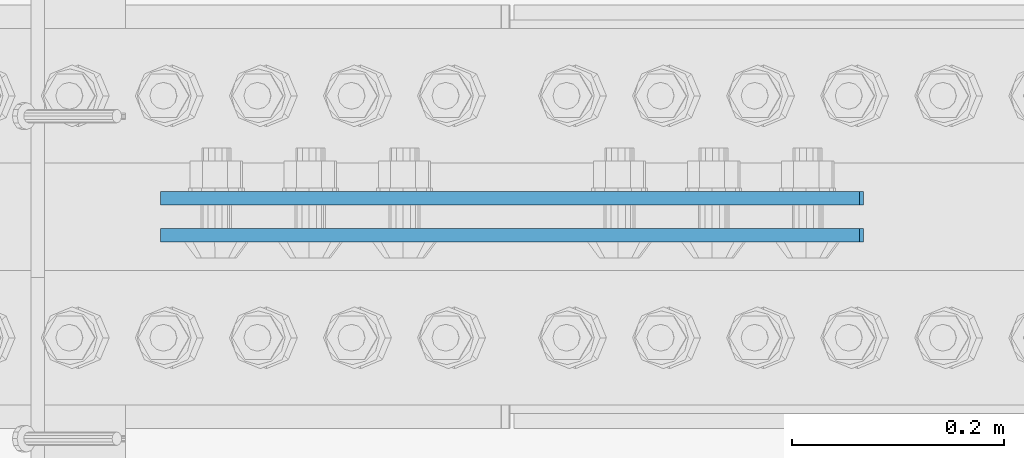
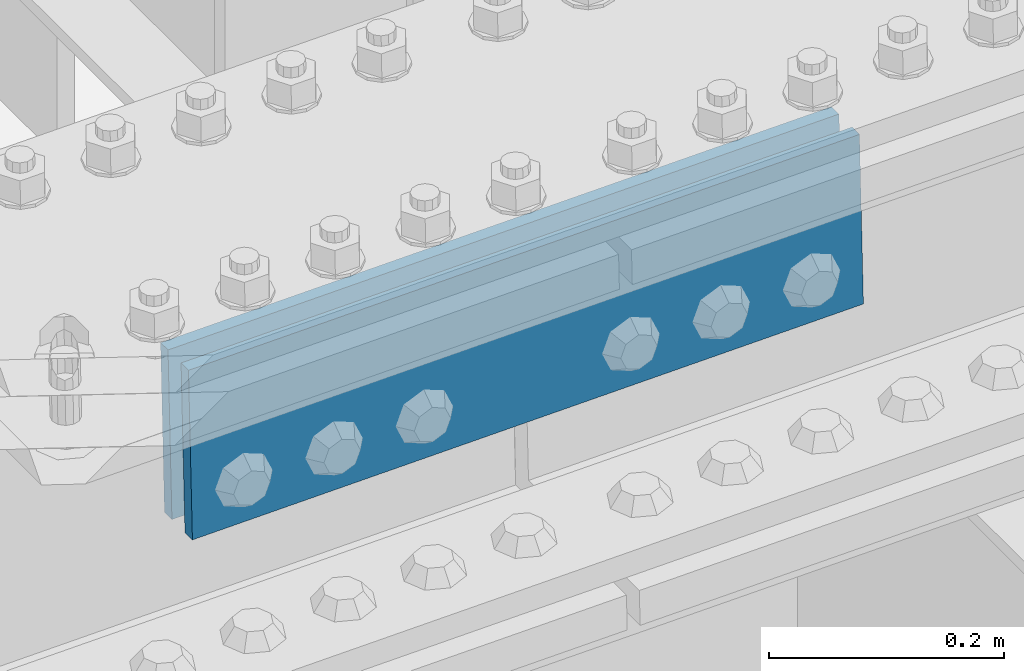
# One storey, part 2526 of 3843: 2 beams, 1 element without a shape of its own.
"""IFC2X3 building model written with IfcOpenShell, lengths in millimetres."""

import ifcopenshell
import ifcopenshell.guid

model = None  # the IFC model being written
_history = None  # IfcOwnerHistory: only IFC2X3 demands one
_inside = {}  # id of a spatial element -> (the spatial element, [elements in it])
_under = {}  # id of a project, library or spatial element -> (it, [spatial elements below it])
_declared = {}  # id of a project -> (the project, [libraries it declares])
_typed = {}  # id of a type object -> (the type object, [elements of that type])
_made_of = {}  # id of a material, layer set ... -> (it, [elements and type objects made of it])


def new_model(schema):
    """Start an empty IFC model of exactly this schema.

    Asked for "IFC4X3", IfcOpenShell would pick the latest addendum, in which some entities
    have other attributes; the version numbers below select the first issue.
    IFC2X3 requires an IfcOwnerHistory on every rooted entity: one is made here for all.
    """
    global model, _history
    if schema == "IFC4X3":
        model = ifcopenshell.file(schema_version=(4, 3, 0, 0))
    else:
        model = ifcopenshell.file(schema=schema)
    _inside.clear()
    _under.clear()
    _declared.clear()
    _typed.clear()
    _made_of.clear()
    _history = None
    if model.schema == "IFC2X3":
        org = make("IfcOrganization", Name="unknown")
        user = make(
            "IfcPersonAndOrganization",
            ThePerson=make("IfcPerson", FamilyName="unknown"),
            TheOrganization=org,
        )
        app = make(
            "IfcApplication",
            ApplicationDeveloper=org,
            Version="unknown",
            ApplicationFullName="unknown",
            ApplicationIdentifier="unknown",
        )
        _history = make(
            "IfcOwnerHistory",
            OwningUser=user,
            OwningApplication=app,
            ChangeAction="ADDED",
            CreationDate=0,
        )
    return model


def make(cls, **values):
    """One entity of the class cls with the attributes given. An attribute that is None is left unset."""
    return model.create_entity(
        cls, **{name: value for name, value in values.items() if value is not None}
    )


def rooted(cls, **values):
    """An entity with a GlobalId (a new one), such as an element, a storey or a relation."""
    return make(cls, GlobalId=ifcopenshell.guid.new(), OwnerHistory=_history, **values)


def si_unit(unit_type, name, prefix=None):
    """IfcSIUnit, for example si_unit("LENGTHUNIT", "METRE", prefix="MILLI")."""
    return make("IfcSIUnit", UnitType=unit_type, Prefix=prefix, Name=name)


def assignment(units):
    """IfcUnitAssignment: the units of a project."""
    return None if units is None else make("IfcUnitAssignment", Units=units)


def point(xyz):
    """IfcCartesianPoint."""
    return None if xyz is None else make("IfcCartesianPoint", Coordinates=xyz)


def direction(xyz):
    """IfcDirection."""
    return None if xyz is None else make("IfcDirection", DirectionRatios=xyz)


def frame(location, z_axis=None, x_axis=None):
    """IfcAxis2Placement3D, a coordinate frame: its origin and axes. An axis left out is left unset."""
    return make(
        "IfcAxis2Placement3D",
        Location=point(location),
        Axis=direction(z_axis),
        RefDirection=direction(x_axis),
    )


def origin_with_axes():
    """The frame at (0, 0, 0) with the z axis (0, 0, 1) and the x axis (1, 0, 0) written out."""
    return frame((0.0, 0.0, 0.0), z_axis=(0.0, 0.0, 1.0), x_axis=(1.0, 0.0, 0.0))


def place(relative_to, where):
    """IfcLocalPlacement: puts the frame where relative to a parent placement (None: the world)."""
    return make(
        "IfcLocalPlacement", PlacementRelTo=relative_to, RelativePlacement=where
    )


def context(
    kind, dimensions, precision=None, world=None, true_north=None, identifier=None
):
    """IfcGeometricRepresentationContext, for example the 3D "Model" context."""
    return make(
        "IfcGeometricRepresentationContext",
        ContextIdentifier=identifier,
        ContextType=kind,
        CoordinateSpaceDimension=dimensions,
        Precision=precision,
        WorldCoordinateSystem=world,
        TrueNorth=true_north,
    )


def subcontext(parent, identifier, kind, view, scale=None):
    """IfcGeometricRepresentationSubContext, for example "Body" below "Model"."""
    return make(
        "IfcGeometricRepresentationSubContext",
        ContextIdentifier=identifier,
        ContextType=kind,
        ParentContext=parent,
        TargetScale=scale,
        TargetView=view,
    )


def project(units=None, contexts=None):
    """IfcProject with its units and contexts."""
    return rooted(
        "IfcProject",
        Name="project",
        RepresentationContexts=contexts,
        UnitsInContext=assignment(units),
    )


def spatial(cls, under=None, at=None, **own):
    """A site, building, storey or space (cls), placed at a placement, below another one or the project."""
    s = rooted(cls, ObjectPlacement=at, **own)
    if under is not None:
        _under.setdefault(under.id(), (under, []))[1].append(s)
    return s


def faces_of(points, faces, orient=None, outer=None):
    """IfcFace entities. A face is a list of loops; a loop is a list of indices into points, from 0.

    orient and outer hold one flag for each loop. By default every Orientation is true, the
    first loop of a face is its IfcFaceOuterBound and the others are IfcFaceBound.
    """
    made = []
    for i, loops in enumerate(faces):
        bounds = []
        for j, loop in enumerate(loops):
            is_outer = j == 0 if outer is None else outer[i][j]
            bounds.append(
                make(
                    "IfcFaceOuterBound" if is_outer else "IfcFaceBound",
                    Bound=make("IfcPolyLoop", Polygon=[points[k] for k in loop]),
                    Orientation=True if orient is None else orient[i][j],
                )
            )
        made.append(make("IfcFace", Bounds=bounds))
    return made


def faceted_brep(points, faces, orient=None, outer=None, voids=None):
    """IfcFacetedBrep: a solid bounded by flat faces; with voids (closed shells), ...WithVoids."""
    shared = [point(p) for p in points]
    hull = make("IfcClosedShell", CfsFaces=faces_of(shared, faces, orient, outer))
    if voids is None:
        return make("IfcFacetedBrep", Outer=hull)
    return make(
        "IfcFacetedBrepWithVoids",
        Outer=hull,
        Voids=[
            make(cls, CfsFaces=faces_of(shared, fs, o, b)) for cls, fs, o, b in voids
        ],
    )


def shape(context_of_items, identifier, shape_type, items):
    """IfcShapeRepresentation: the items that make up one representation, for example the "Body"."""
    return make(
        "IfcShapeRepresentation",
        ContextOfItems=context_of_items,
        RepresentationIdentifier=identifier,
        RepresentationType=shape_type,
        Items=items,
    )


def material(Name=None, Category=None):
    """IfcMaterial."""
    return make("IfcMaterial", Name=Name, Category=Category)


def made_of(thing, what):
    """Note that an element or type object is made of a material, layer set ...; save() writes the relation."""
    if what is not None:
        _made_of.setdefault(what.id(), (what, []))[1].append(thing)
    return thing


def type_object(cls, material=None, **own):
    """A type object (cls), such as IfcWallType, which elements share."""
    return made_of(rooted(cls, **own), material)


def element(
    cls,
    number,
    at=None,
    inside=None,
    cuts=None,
    type_object=None,
    material=None,
    context=None,
    identifier="Body",
    shape_type=None,
    held_by="IfcProductDefinitionShape",
    body=None,
    shapes=None,
    **own,
):
    """One element of the class cls, such as IfcWall. Its Tag is "e" and its number.

    at: its placement. inside: the storey or other place that contains it. cuts: it is an
    opening in that element (IfcRelVoidsElement). A single representation is given by context,
    identifier, shape_type and body (its items); several are given by shapes. held_by: the class
    of the entity that holds the representations. save() writes the other relations.
    """
    e = rooted(cls, Tag="e%d" % number, ObjectPlacement=at, **own)
    if body is not None:
        shapes = [shape(context, identifier, shape_type, body)]
    if shapes is not None:
        e.Representation = make(held_by, Representations=shapes)
    if inside is not None:
        _inside.setdefault(inside.id(), (inside, []))[1].append(e)
    if cuts is not None:
        rooted(
            "IfcRelVoidsElement", RelatingBuildingElement=cuts, RelatedOpeningElement=e
        )
    if type_object is not None:
        _typed.setdefault(type_object.id(), (type_object, []))[1].append(e)
    return made_of(e, material)


def aggregate(whole, parts):
    """IfcRelAggregates: a whole, such as a stair, and the parts it consists of."""
    return rooted("IfcRelAggregates", RelatingObject=whole, RelatedObjects=parts)


def save(model, path):
    """Write the relations noted so far, then the file.

    IfcRelAggregates (storeys below a building ...), IfcRelContainedInSpatialStructure (elements
    in a storey), IfcRelDefinesByType, IfcRelAssociatesMaterial and IfcRelDeclares: one each for
    every whole, place, type object, material and project.
    """
    for whole, parts in _under.values():
        aggregate(whole, parts)
    for where, things in _inside.values():
        rooted(
            "IfcRelContainedInSpatialStructure",
            RelatedElements=things,
            RelatingStructure=where,
        )
    for kind, things in _typed.values():
        rooted("IfcRelDefinesByType", RelatedObjects=things, RelatingType=kind)
    for what, things in _made_of.values():
        rooted("IfcRelAssociatesMaterial", RelatedObjects=things, RelatingMaterial=what)
    for by, libraries in _declared.values():
        rooted("IfcRelDeclares", RelatingContext=by, RelatedDefinitions=libraries)
    model.write(path)


model = new_model("IFC2X3")

# Units and contexts
model_context = context("Model", 3, precision=1e-05, world=origin_with_axes())
body_context = subcontext(model_context, "Body", "Model", "MODEL_VIEW")
ifc_project = project(units=[si_unit("LENGTHUNIT", "METRE", prefix="MILLI"), si_unit("AREAUNIT", "SQUARE_METRE"), si_unit("VOLUMEUNIT", "CUBIC_METRE"), si_unit("MASSUNIT", "GRAM", prefix="KILO"), si_unit("TIMEUNIT", "SECOND"), si_unit("PLANEANGLEUNIT", "RADIAN"), si_unit("SOLIDANGLEUNIT", "STERADIAN"), si_unit("THERMODYNAMICTEMPERATUREUNIT", "DEGREE_CELSIUS"), si_unit("LUMINOUSINTENSITYUNIT", "LUMEN")], contexts=[model_context])

# Site, building, storey
site_placement = place(None, origin_with_axes())
site = spatial("IfcSite", under=ifc_project, at=site_placement, CompositionType="ELEMENT")
building_placement = place(site_placement, origin_with_axes())
building = spatial("IfcBuilding", under=site, at=building_placement, Name="Undefined", CompositionType="ELEMENT")
storey_placement = place(building_placement, origin_with_axes())
storey = spatial("IfcBuildingStorey", under=building, at=storey_placement, Name="Undefined", CompositionType="ELEMENT", Elevation=0.0)

# Assembly, beams
assembly_placement = place(storey_placement, origin_with_axes())
assembly = element("IfcElementAssembly", 1, at=assembly_placement, inside=storey, Name="BEAM", AssemblyPlace="NOTDEFINED", PredefinedType="RIGID_FRAME")
ifc_material = material(Name="STEEL/A572-50")
beam_type = type_object("IfcBeamType", PredefinedType="NOTDEFINED")
beam_1_placement = place(assembly_placement, frame((65180.7359843514, 84002.5625, 45840.4657396721), z_axis=(-0.0216342480057937, 0.0, 0.999765952267441), x_axis=(0.999765952267441, 0.0, 0.0216342480057898)))
beam_1 = element("IfcBeam", 2, at=beam_1_placement, type_object=beam_type, material=ifc_material, Name="PLATE", context=body_context, shape_type="Brep", body=[
    faceted_brep([(1.45519152283669e-11, 6.35000000000582, -88.8999999998996), (0.0, 6.34999999999854, 88.9000015258789), (660.399999982677, 6.35000000000582, 88.8999999999651), (660.399999982707, 6.35000000000582, -88.8999999998268), (0.0, -6.34999999999854, 88.9000015258789), (660.399999982677, -6.35000000000582, 88.8999999999651), (1.45519152283669e-11, -6.35000000000582, -88.8999999998996), (660.399999982707, -6.35000000000582, -88.8999999998268)], [[[0, 1, 2, 3]], [[1, 4, 5, 2]], [[4, 6, 7, 5]], [[6, 0, 3, 7]], [[5, 7, 3, 2]], [[6, 4, 1, 0]]]),
])
beam_2_placement = place(assembly_placement, frame((65180.7359843514, 83967.6375, 45840.4657396721), z_axis=(-0.0216342480057937, 0.0, 0.999765952267441), x_axis=(0.999765952267441, 0.0, 0.0216342480057898)))
beam_2 = element("IfcBeam", 3, at=beam_2_placement, type_object=beam_type, material=ifc_material, Name="PLATE", context=body_context, shape_type="Brep", body=[
    faceted_brep([(1.45519152283669e-11, 6.35000000000582, -88.8999999998996), (0.0, 6.34999999999854, 88.9000015258789), (660.399999982677, 6.35000000000582, 88.8999999999651), (660.399999982707, 6.35000000000582, -88.8999999998268), (0.0, -6.34999999999854, 88.9000015258789), (660.399999982677, -6.35000000000582, 88.8999999999651), (1.45519152283669e-11, -6.35000000000582, -88.8999999998996), (660.399999982707, -6.35000000000582, -88.8999999998268)], [[[0, 1, 2, 3]], [[1, 4, 5, 2]], [[4, 6, 7, 5]], [[6, 0, 3, 7]], [[5, 7, 3, 2]], [[6, 4, 1, 0]]]),
])
aggregate(assembly, [beam_1, beam_2])

save(model, "model.ifc")
